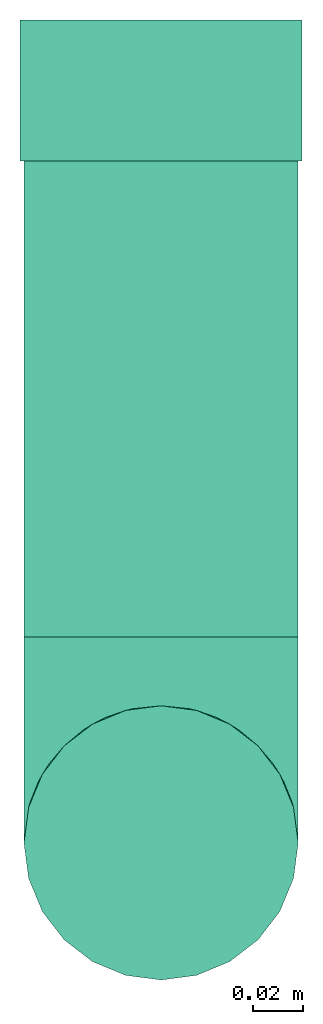
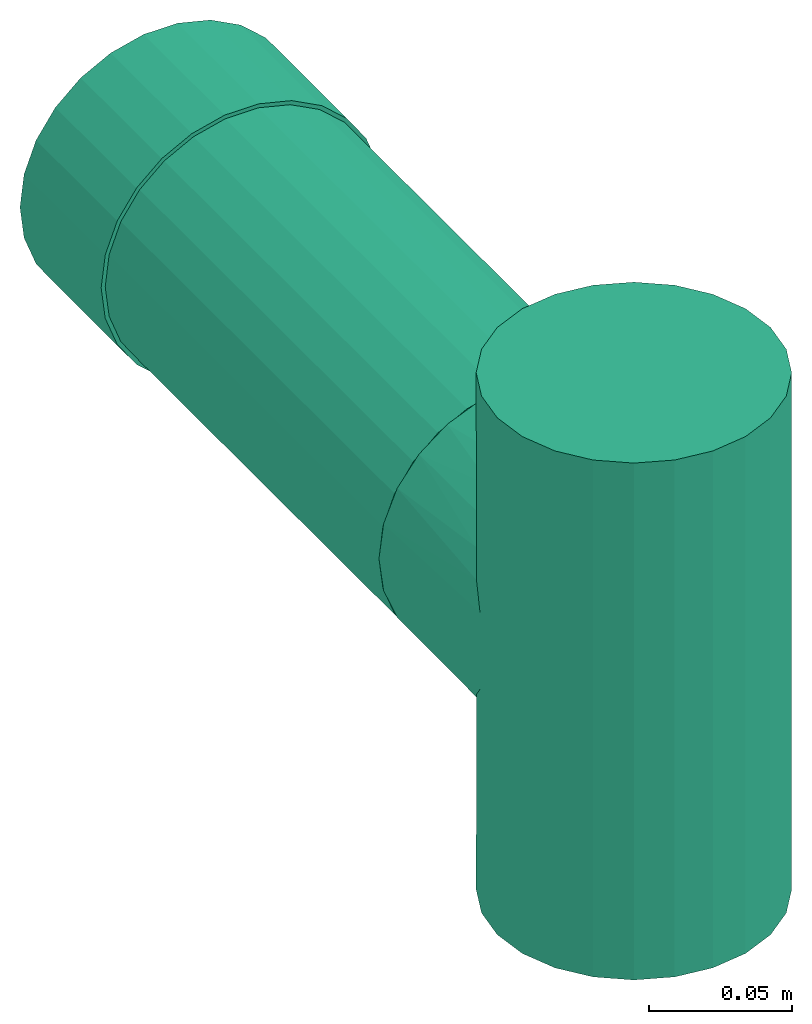
# One storey: 2 flow fittings, 1 flow segment.
"""IFC2X3 building model written with IfcOpenShell, lengths in millimetres."""

from ifc_helpers import new_model, entity, si_unit, converted_unit, derived_unit, direction, frame, frame_2d, origin, origin_2d_with_axis, place, context, subcontext, project, spatial, circle, extrude, faceted_brep, source, transform, mapped, type_object, type_shapes, element, save


model = new_model("IFC2X3")

# Units and contexts
model_context = context("Model", 3, precision=0.01, world=origin(), true_north=direction((6.12303176911189e-17, 1.0)))
body_context = subcontext(model_context, "Body", "Model", "MODEL_VIEW")
ifc_project = project(units=[si_unit("LENGTHUNIT", "METRE", prefix="MILLI"), si_unit("AREAUNIT", "SQUARE_METRE"), si_unit("VOLUMEUNIT", "CUBIC_METRE"), converted_unit("PLANEANGLEUNIT", "DEGREE", entity("IfcRatioMeasure", 0.0174532925199433), si_unit("PLANEANGLEUNIT", "RADIAN"), dimensions=[0, 0, 0, 0, 0, 0, 0]), si_unit("MASSUNIT", "GRAM", prefix="KILO"), derived_unit("MASSDENSITYUNIT", [(si_unit("MASSUNIT", "GRAM", prefix="KILO"), 1), (si_unit("LENGTHUNIT", "METRE"), -3)]), si_unit("TIMEUNIT", "SECOND"), si_unit("FREQUENCYUNIT", "HERTZ"), si_unit("THERMODYNAMICTEMPERATUREUNIT", "DEGREE_CELSIUS"), derived_unit("THERMALTRANSMITTANCEUNIT", [(si_unit("MASSUNIT", "GRAM", prefix="KILO"), 1), (si_unit("THERMODYNAMICTEMPERATUREUNIT", "KELVIN"), -1), (si_unit("TIMEUNIT", "SECOND"), -3)]), derived_unit("VOLUMETRICFLOWRATEUNIT", [(si_unit("LENGTHUNIT", "METRE"), 3), (si_unit("TIMEUNIT", "SECOND"), -1)]), si_unit("ELECTRICCURRENTUNIT", "AMPERE"), si_unit("ELECTRICVOLTAGEUNIT", "VOLT"), si_unit("POWERUNIT", "WATT"), si_unit("FORCEUNIT", "NEWTON", prefix="KILO"), si_unit("ILLUMINANCEUNIT", "LUX"), si_unit("LUMINOUSFLUXUNIT", "LUMEN"), si_unit("LUMINOUSINTENSITYUNIT", "CANDELA"), derived_unit("USERDEFINED", [(si_unit("MASSUNIT", "GRAM", prefix="KILO"), -1), (si_unit("LENGTHUNIT", "METRE"), -2), (si_unit("TIMEUNIT", "SECOND"), 3), (si_unit("LUMINOUSFLUXUNIT", "LUMEN"), 1)]), derived_unit("LINEARVELOCITYUNIT", [(si_unit("LENGTHUNIT", "METRE"), 1), (si_unit("TIMEUNIT", "SECOND"), -1)]), si_unit("PRESSUREUNIT", "PASCAL"), derived_unit("USERDEFINED", [(si_unit("LENGTHUNIT", "METRE"), -2), (si_unit("MASSUNIT", "GRAM", prefix="KILO"), 1), (si_unit("TIMEUNIT", "SECOND"), -2)])], contexts=[model_context])

# Site, building, storey
site_placement = place(None, origin())
site = spatial("IfcSite", under=ifc_project, at=site_placement, CompositionType="ELEMENT")
building_placement = place(site_placement, origin())
building = spatial("IfcBuilding", under=site, at=building_placement, CompositionType="ELEMENT")
storey_placement = place(building_placement, origin())
storey = spatial("IfcBuildingStorey", under=building, at=storey_placement, Name="00 Ground level", CompositionType="ELEMENT", Elevation=0.0)

# Flow segment
pipe_segment_type = type_object("IfcPipeSegmentType", Name="Pipe Types", PredefinedType="NOTDEFINED")
flow_segment_placement = place(storey_placement, frame((30783.1932668086, -68078.3241905963, 943.404727764085)))
element("IfcFlowSegment", 1, at=flow_segment_placement, inside=storey, type_object=pipe_segment_type, Name="Pipe Types", ObjectType="Pipe Types", context=body_context, shape_type="SweptSolid", body=[
    extrude(circle(Radius=55.0, at=origin_2d_with_axis()), frame((56.5952722359164, 0.0, 56.595272235916), z_axis=(0.0, 1.0, 0.0), x_axis=(1.0, 0.0, 0.0)), (0.0, 0.0, 1.0), 190.972824049356),
])

# Flow fittings
pipe_fitting_type_1 = type_object("IfcPipeFittingType", Name="pipe_fe_tee_90_001", PredefinedType="NOTDEFINED")
shared_shape_1 = source(origin(), body_context, "Body", "Brep", [
    faceted_brep([(-110.0, 27.5000000000003, -47.6313972081441), (-110.0, 14.235047480639, -53.1259204458987), (-110.0, 0.0, -55.0), (-110.0, -14.2350474806383, -53.1259204458988), (-110.0, -27.4999999999996, -47.6313972081442), (-110.0, -33.1954364826297, -43.2611350867022), (-110.0, -38.8908729652597, -38.8908729652602), (-110.0, -43.2611350867018, -33.1954364826302), (-110.0, -47.6313972081438, -27.5000000000001), (-110.0, -50.3786588270211, -20.8675237403194), (-110.0, -53.1259204458984, -14.2350474806388), (-110.0, -54.0629602229491, -7.11752374031947), (-110.0, -55.0, 0.0), (-110.0, -54.0629602229492, 7.11752374031898), (-110.0, -53.1259204458986, 14.2350474806381), (-110.0, -50.3786588270214, 20.8675237403188), (-110.0, -47.6313972081441, 27.4999999999995), (-110.0, -43.2611350867022, 33.1954364826296), (-110.0, -38.8908729652602, 38.8908729652597), (-110.0, -33.1954364826302, 43.2611350867018), (-110.0, -27.5000000000002, 47.6313972081438), (-110.0, -14.2350474806389, 53.1259204458986), (-110.0, 0.0, 55.0), (-110.0, 14.2350474806383, 53.1259204458989), (-110.0, 27.4999999999997, 47.6313972081444), (-110.0, 38.8908729652599, 38.8908729652606), (-110.0, 47.6313972081441, 27.5000000000006), (-110.0, 53.1259204458989, 14.2350474806393), (-110.0, 55.0, 0.0), (-110.0, 53.125920445899, -14.2350474806386), (-110.0, 47.6313972081444, -27.5), (-110.0, 38.8908729652604, -38.8908729652601), (110.0, 0.0, -55.0), (110.0, 14.2350474806383, -53.1259204458987), (110.0, 27.4999999999996, -47.6313972081441), (110.0, 38.8908729652597, -38.8908729652601), (110.0, 47.6313972081437, -27.5), (110.0, 53.1259204458983, -14.2350474806386), (110.0, 55.0, 0.0), (110.0, 53.1259204458982, 14.2350474806393), (110.0, 47.6313972081434, 27.5000000000006), (110.0, 38.8908729652592, 38.8908729652606), (110.0, 27.499999999999, 47.6313972081444), (110.0, 14.2350474806376, 53.1259204458989), (110.0, 0.0, 55.0), (110.0, -14.2350474806396, 53.1259204458986), (110.0, -27.5000000000009, 47.6313972081438), (110.0, -33.1954364826309, 43.2611350867018), (110.0, -38.8908729652609, 38.8908729652597), (110.0, -43.2611350867029, 33.1954364826296), (110.0, -47.6313972081448, 27.4999999999995), (110.0, -50.3786588270221, 20.8675237403188), (110.0, -53.1259204458993, 14.2350474806381), (110.0, -54.0629602229499, 7.11752374031896), (110.0, -55.0, 0.0), (110.0, -54.0629602229498, -7.11752374031947), (110.0, -53.1259204458991, -14.2350474806388), (110.0, -50.3786588270218, -20.8675237403195), (110.0, -47.6313972081445, -27.5000000000001), (110.0, -43.2611350867024, -33.1954364826302), (110.0, -38.8908729652604, -38.8908729652602), (110.0, -33.1954364826304, -43.2611350867022), (110.0, -27.5000000000003, -47.6313972081442), (110.0, -14.235047480639, -53.1259204458988), (53.780443600281, -53.7804436002813, 11.5179809930815), (54.3902218001405, -54.3902218001408, 5.75899049654068), (50.3569451821954, -50.3569451821957, 22.1173703662385), (38.9627561846374, -38.9627561846376, 38.8188566356159), (31.8898295358707, -31.8898295358709, 44.8111456244214), (-54.3902218001406, -54.3902218001404, 5.75899049654068), (45.247564911309, -45.2475649113092, 31.267521001782), (-53.7804436002811, -53.780443600281, 11.5179809930815), (-50.3569451821955, -50.3569451821954, 22.1173703662384), (-55.0, -55.0, 0.0), (55.0, -55.0, 0.0), (-31.8898295358708, -31.8898295358708, 44.8111456244214), (-38.9627561846374, -38.9627561846373, 38.8188566356159), (-45.247564911309, -45.2475649113089, 31.267521001782), (-24.2945605988947, -24.2945605988946, 49.3434324435039), (24.2945605988946, -24.2945605988948, 49.3434324435039), (8.22722382923395, -8.22722382923404, 54.3811804585344), (16.3614781538201, -16.3614781538203, 52.510018402416), (0.0, 0.0, 55.0), (-8.227223829234, -8.22722382923398, 54.3811804585344), (-16.3614781538202, -16.3614781538202, 52.510018402416), (0.0, 0.0, -55.0), (8.22722382923376, -8.2272238292339, -54.3811804585344), (-54.3902218001405, -54.3902218001404, -5.75899049654098), (54.3902218001405, -54.3902218001407, -5.75899049654099), (-8.22722382923383, -8.22722382923384, -54.3811804585344), (16.36147815382, -16.3614781538201, -52.510018402416), (-45.2475649113089, -45.2475649113088, -31.2675210017822), (31.8898295358706, -31.8898295358708, -44.8111456244216), (-50.3569451821954, -50.3569451821952, -22.1173703662387), (-38.9627561846373, -38.9627561846372, -38.818856635616), (-31.8898295358707, -31.8898295358706, -44.8111456244215), (-16.36147815382, -16.36147815382, -52.510018402416), (-24.2945605988945, -24.2945605988944, -49.343432443504), (24.2945605988944, -24.2945605988946, -49.343432443504), (38.9627561846372, -38.9627561846374, -38.8188566356161), (-53.780443600281, -53.7804436002809, -11.5179809930818), (45.2475649113088, -45.2475649113091, -31.2675210017822), (50.3569451821953, -50.3569451821956, -22.1173703662387), (53.780443600281, -53.7804436002812, -11.5179809930818), (0.0, -82.4999999999999, -55.0), (14.2350474806387, -82.4999999999999, -53.1259204458987), (27.5, -82.4999999999999, -47.6313972081441), (38.8908729652601, -82.4999999999999, -38.8908729652601), (47.6313972081441, -82.4999999999999, -27.5), (53.1259204458987, -82.4999999999999, -14.2350474806386), (55.0, -82.4999999999999, 0.0), (53.1259204458986, -82.4999999999999, 14.2350474806393), (47.6313972081438, -82.4999999999999, 27.5000000000006), (38.8908729652596, -82.4999999999999, 38.8908729652606), (27.4999999999994, -82.4999999999999, 47.6313972081444), (14.235047480638, -82.4999999999999, 53.1259204458989), (0.0, -82.4999999999999, 55.0), (-14.2350474806392, -82.4999999999999, 53.1259204458986), (-27.5000000000005, -82.4999999999999, 47.6313972081438), (-38.8908729652605, -82.4999999999999, 38.8908729652597), (-47.6313972081444, -82.4999999999999, 27.4999999999995), (-53.1259204458989, -82.4999999999999, 14.2350474806381), (-55.0, -82.4999999999999, 0.0), (-53.1259204458987, -82.4999999999999, -14.2350474806388), (-47.6313972081441, -82.4999999999999, -27.5000000000001), (-38.8908729652601, -82.4999999999999, -38.8908729652602), (-27.4999999999999, -82.4999999999999, -47.6313972081442), (-14.2350474806386, -82.4999999999999, -53.1259204458988)], [[[0, 1, 2, 3, 4, 5, 6, 7, 8, 9, 10, 11, 12, 13, 14, 15, 16, 17, 18, 19, 20, 21, 22, 23, 24, 25, 26, 27, 28, 29, 30, 31]], [[32, 33, 34, 35, 36, 37, 38, 39, 40, 41, 42, 43, 44, 45, 46, 47, 48, 49, 50, 51, 52, 53, 54, 55, 56, 57, 58, 59, 60, 61, 62, 63]], [[53, 52, 64]], [[54, 53, 65]], [[66, 64, 52]], [[51, 50, 66, 52]], [[49, 48, 67]], [[68, 47, 46]], [[12, 69, 13]], [[70, 49, 67]], [[67, 48, 47]], [[70, 50, 49]], [[50, 70, 66]], [[67, 47, 68]], [[71, 72, 14]], [[13, 69, 71]], [[69, 12, 73]], [[54, 65, 74]], [[72, 16, 15, 14]], [[75, 19, 76]], [[76, 18, 17]], [[77, 17, 16]], [[76, 19, 18]], [[20, 75, 78]], [[77, 16, 72]], [[53, 64, 65]], [[68, 46, 79]], [[45, 44, 80]], [[71, 14, 13]], [[81, 79, 45]], [[80, 81, 45]], [[76, 17, 77]], [[80, 44, 82]], [[83, 82, 22]], [[45, 79, 46]], [[26, 25, 41, 40]], [[27, 26, 40, 39]], [[24, 23, 43, 42]], [[25, 24, 42, 41]], [[43, 23, 22, 82, 44]], [[28, 27, 39, 38]], [[84, 83, 21]], [[84, 21, 78]], [[21, 83, 22]], [[78, 21, 20]], [[75, 20, 19]], [[31, 30, 36, 35]], [[29, 37, 36, 30]], [[28, 38, 37, 29]], [[0, 31, 35, 34]], [[85, 2, 1, 33, 32]], [[86, 32, 63]], [[12, 87, 73]], [[54, 74, 88]], [[86, 85, 32]], [[2, 85, 89]], [[90, 86, 63]], [[91, 8, 7]], [[92, 62, 61]], [[34, 33, 1, 0]], [[93, 10, 9, 8]], [[94, 5, 95]], [[96, 97, 3]], [[89, 96, 3]], [[2, 89, 3]], [[97, 4, 3]], [[90, 63, 98]], [[60, 99, 61]], [[11, 100, 87]], [[92, 61, 99]], [[99, 60, 59]], [[59, 58, 101]], [[62, 92, 98]], [[102, 58, 57, 56]], [[103, 102, 56]], [[103, 55, 88]], [[58, 102, 101]], [[103, 56, 55]], [[94, 6, 5]], [[95, 4, 97]], [[95, 5, 4]], [[94, 91, 7]], [[94, 7, 6]], [[54, 88, 55]], [[99, 59, 101]], [[12, 11, 87]], [[93, 100, 10]], [[10, 100, 11]], [[93, 8, 91]], [[62, 98, 63]], [[104, 105, 106, 107, 108, 109, 110, 111, 112, 113, 114, 115, 116, 117, 118, 119, 120, 121, 122, 123, 124, 125, 126, 127]], [[122, 121, 71]], [[122, 71, 69, 73]], [[71, 121, 72]], [[119, 118, 75]], [[77, 120, 119]], [[72, 121, 120]], [[78, 118, 117]], [[77, 72, 120]], [[75, 76, 119]], [[77, 119, 76]], [[84, 78, 117]], [[116, 82, 83]], [[84, 117, 83]], [[75, 118, 78]], [[83, 117, 116]], [[114, 79, 115]], [[115, 80, 116]], [[68, 114, 113]], [[64, 111, 110]], [[113, 112, 70]], [[111, 66, 112]], [[110, 74, 65, 64]], [[68, 79, 114]], [[81, 80, 115]], [[79, 81, 115]], [[64, 66, 111]], [[70, 67, 113]], [[66, 70, 112]], [[68, 113, 67]], [[116, 80, 82]], [[110, 109, 103]], [[110, 103, 88, 74]], [[103, 109, 102]], [[101, 108, 107]], [[107, 106, 92]], [[102, 109, 108]], [[98, 106, 105]], [[101, 102, 108]], [[92, 99, 107]], [[101, 107, 99]], [[90, 98, 105]], [[104, 85, 86]], [[90, 105, 86]], [[92, 106, 98]], [[86, 105, 104]], [[126, 97, 127]], [[127, 89, 104]], [[95, 126, 125]], [[100, 123, 122]], [[125, 124, 91]], [[123, 93, 124]], [[122, 73, 87, 100]], [[95, 97, 126]], [[96, 89, 127]], [[97, 96, 127]], [[100, 93, 123]], [[91, 94, 125]], [[93, 91, 124]], [[95, 125, 94]], [[104, 89, 85]]]),
])
type_shapes(pipe_fitting_type_1, [shared_shape_1])
flow_fitting_1_placement = place(storey_placement, frame((30839.7885390445, -68160.8241905963, 1000.0), z_axis=(1.0, 0.0, 0.0), x_axis=(0.0, 0.0, 1.0)))
element("IfcFlowFitting", 2, at=flow_fitting_1_placement, inside=storey, type_object=pipe_fitting_type_1, Name="pipe_fe_tee_90_001:pipe_fe_tee_90_001", ObjectType="pipe_fe_tee_90_001:pipe_fe_tee_90_001", context=body_context, shape_type="MappedRepresentation", body=[
    mapped(shared_shape_1, transform((0.0, 0.0, 0.0), scale=1.0)),
])
pipe_fitting_type_2 = type_object("IfcPipeFittingType", Name="Standard", PredefinedType="NOTDEFINED")
shared_shape_2 = source(origin(), body_context, "Body", "SweptSolid", [
    extrude(circle(Radius=56.5875, at=frame_2d((0.0, -9.1419628605704e-14), x_axis=(1.0, 0.0))), frame((-28.2937499999937, 0.0, 0.0), z_axis=(1.0, 0.0, 0.0), x_axis=(0.0, 1.0, 0.0)), (0.0, 0.0, 1.0), 56.5875),
])
type_shapes(pipe_fitting_type_2, [shared_shape_2])
flow_fitting_2_placement = place(storey_placement, frame((30839.7885390445, -67859.057616547, 1000.0), z_axis=(0.0, 0.0, 1.0), x_axis=(0.0, 1.0, 0.0)))
element("IfcFlowFitting", 3, at=flow_fitting_2_placement, inside=storey, type_object=pipe_fitting_type_2, Name="M_Coupling - Generic:Standard", ObjectType="M_Coupling - Generic:Standard", context=body_context, shape_type="MappedRepresentation", body=[
    mapped(shared_shape_2, transform((0.0, 0.0, 0.0), scale=1.0)),
])

save(model, "model.ifc")
